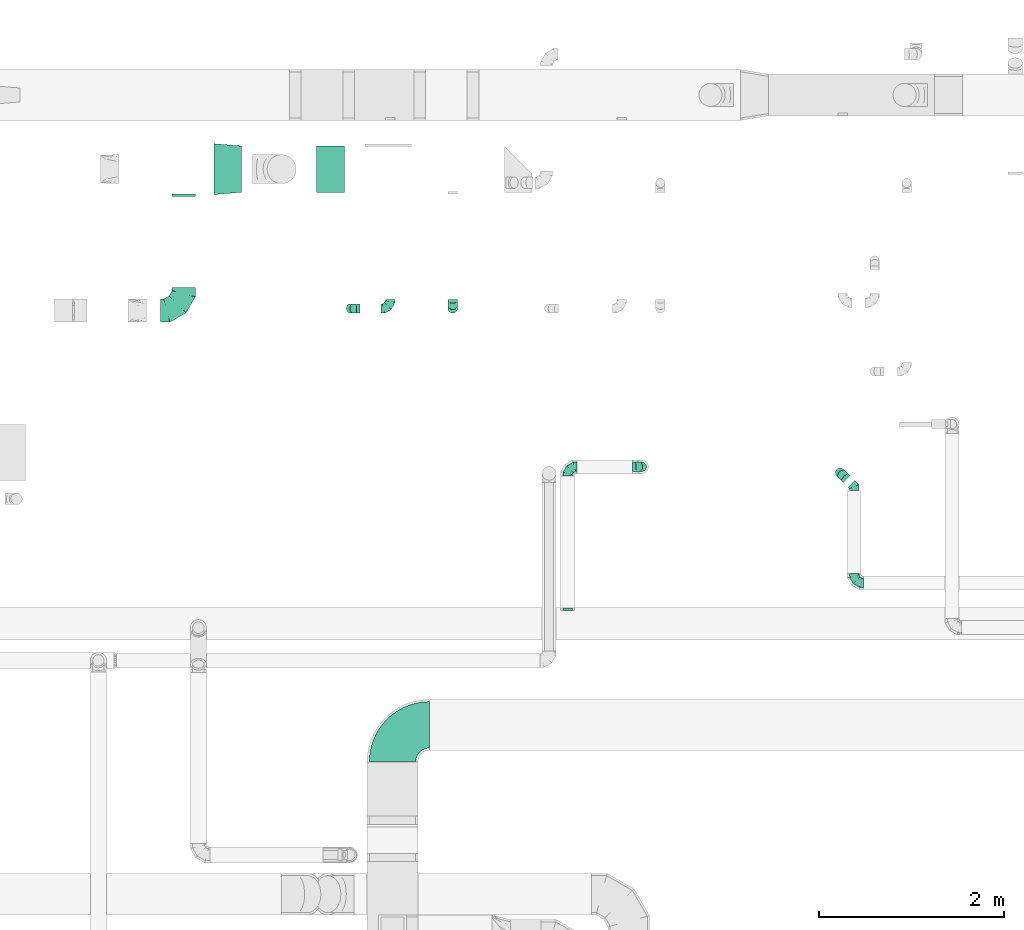
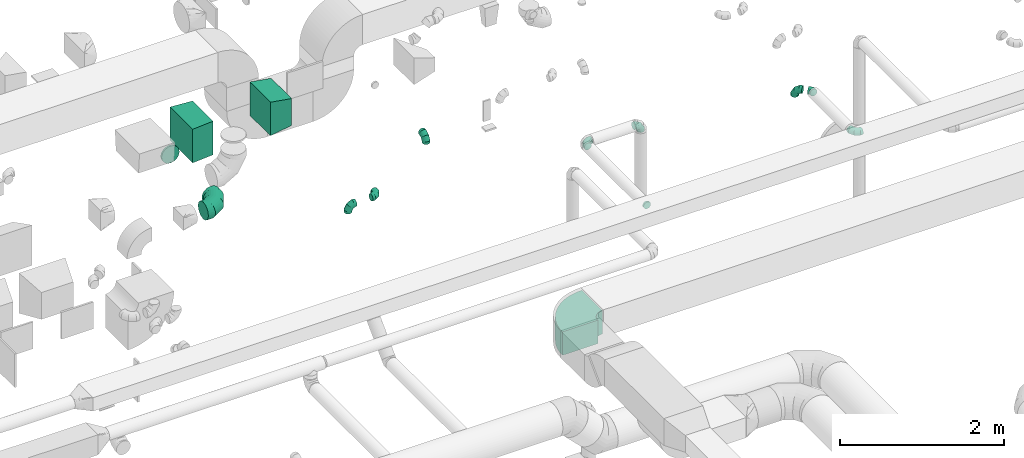
# One storey, part 59 of 97: 14 flow fittings.
"""IFC2X3 building model written with IfcOpenShell, lengths in millimetres."""

from ifc_helpers import new_model, entity, si_unit, converted_unit, derived_unit, direction, frame, frame_2d, origin, place, context, subcontext, project, spatial, polyline, circle_curve, parameter, trimmed, segment, composite_curve, outline, extrude, faceted_brep, source, transform, mapped, material, type_object, type_shapes, element, save


model = new_model("IFC2X3")

# Units and contexts
model_context = context("Model", 3, precision=0.01, world=origin(), true_north=direction((6.12303176911189e-17, 1.0)))
body_context = subcontext(model_context, "Body", "Model", "MODEL_VIEW")
ifc_project = project(units=[si_unit("LENGTHUNIT", "METRE", prefix="MILLI"), si_unit("AREAUNIT", "SQUARE_METRE"), si_unit("VOLUMEUNIT", "CUBIC_METRE"), converted_unit("PLANEANGLEUNIT", "DEGREE", entity("IfcRatioMeasure", 0.0174532925199433), si_unit("PLANEANGLEUNIT", "RADIAN"), dimensions=[0, 0, 0, 0, 0, 0, 0]), si_unit("MASSUNIT", "GRAM", prefix="KILO"), derived_unit("MASSDENSITYUNIT", [(si_unit("MASSUNIT", "GRAM", prefix="KILO"), 1), (si_unit("LENGTHUNIT", "METRE"), -3)]), derived_unit("MOMENTOFINERTIAUNIT", [(si_unit("LENGTHUNIT", "METRE"), 4)]), si_unit("TIMEUNIT", "SECOND"), si_unit("FREQUENCYUNIT", "HERTZ"), si_unit("THERMODYNAMICTEMPERATUREUNIT", "DEGREE_CELSIUS"), derived_unit("THERMALTRANSMITTANCEUNIT", [(si_unit("MASSUNIT", "GRAM", prefix="KILO"), 1), (si_unit("THERMODYNAMICTEMPERATUREUNIT", "KELVIN"), -1), (si_unit("TIMEUNIT", "SECOND"), -3)]), derived_unit("VOLUMETRICFLOWRATEUNIT", [(si_unit("LENGTHUNIT", "METRE"), 3), (si_unit("TIMEUNIT", "SECOND"), -1)]), derived_unit("MASSFLOWRATEUNIT", [(si_unit("MASSUNIT", "GRAM", prefix="KILO"), 1), (si_unit("TIMEUNIT", "SECOND"), -1)]), derived_unit("ROTATIONALFREQUENCYUNIT", [(si_unit("TIMEUNIT", "SECOND"), -1)]), si_unit("ELECTRICCURRENTUNIT", "AMPERE"), si_unit("ELECTRICVOLTAGEUNIT", "VOLT"), si_unit("POWERUNIT", "WATT"), si_unit("FORCEUNIT", "NEWTON", prefix="KILO"), si_unit("ILLUMINANCEUNIT", "LUX"), si_unit("LUMINOUSFLUXUNIT", "LUMEN"), si_unit("LUMINOUSINTENSITYUNIT", "CANDELA"), derived_unit("USERDEFINED", [(si_unit("MASSUNIT", "GRAM", prefix="KILO"), -1), (si_unit("LENGTHUNIT", "METRE"), -2), (si_unit("TIMEUNIT", "SECOND"), 3), (si_unit("LUMINOUSFLUXUNIT", "LUMEN"), 1)]), derived_unit("LINEARVELOCITYUNIT", [(si_unit("LENGTHUNIT", "METRE"), 1), (si_unit("TIMEUNIT", "SECOND"), -1)]), si_unit("PRESSUREUNIT", "PASCAL"), derived_unit("USERDEFINED", [(si_unit("LENGTHUNIT", "METRE"), -2), (si_unit("MASSUNIT", "GRAM", prefix="KILO"), 1), (si_unit("TIMEUNIT", "SECOND"), -2)]), derived_unit("LINEARFORCEUNIT", [(si_unit("MASSUNIT", "GRAM", prefix="KILO"), 1), (si_unit("LENGTHUNIT", "METRE"), 1), (si_unit("TIMEUNIT", "SECOND"), -2), (si_unit("LENGTHUNIT", "METRE"), -1)]), derived_unit("PLANARFORCEUNIT", [(si_unit("MASSUNIT", "GRAM", prefix="KILO"), 1), (si_unit("LENGTHUNIT", "METRE"), 1), (si_unit("TIMEUNIT", "SECOND"), -2), (si_unit("LENGTHUNIT", "METRE"), -2)])], contexts=[model_context])

# Site, building, storey
site_placement = place(None, origin())
site = spatial("IfcSite", under=ifc_project, at=site_placement, CompositionType="ELEMENT")
building_placement = place(site_placement, origin())
building = spatial("IfcBuilding", under=site, at=building_placement, CompositionType="ELEMENT")
storey_placement = place(building_placement, frame((0.0, 0.0, -4900.0)))
storey = spatial("IfcBuildingStorey", under=building, at=storey_placement, CompositionType="ELEMENT", Elevation=-4900.0)

# Flow fittings
ifc_material = material()
duct_fitting_type_1 = type_object("IfcDuctFittingType", PredefinedType="NOTDEFINED", material=ifc_material)
shared_shape_1 = source(origin(), body_context, "Body", "SweptSolid", [
    extrude(outline(polyline([(-189.06, -221.94), (115.08, -221.94), (180.84, 172.62), (-106.86, 271.26), (-189.06, -221.94)])), frame((150.0, -250.0, 0.0), z_axis=(0.0, 1.0, 0.0), x_axis=(0.986393923832128, 0.0, -0.16439898730545)), (0.0, 0.0, 1.0), 500.0),
])
type_shapes(duct_fitting_type_1, [shared_shape_1])
flow_fitting_1_placement = place(storey_placement, frame((48645.11, 14548.39, 3800.0)))
element("IfcFlowFitting", 1, at=flow_fitting_1_placement, inside=storey, type_object=duct_fitting_type_1, material=ifc_material, context=body_context, shape_type="MappedRepresentation", body=[
    mapped(shared_shape_1, transform((0.0, 0.0, 0.0), scale=1.0)),
])
duct_fitting_type_2 = type_object("IfcDuctFittingType", PredefinedType="NOTDEFINED", material=ifc_material)
shared_shape_2 = source(origin(), body_context, "Body", "SweptSolid", [
    extrude(outline(polyline([(-172.32, -261.59), (128.72, -261.59), (170.24, 236.68), (-126.64, 286.51), (-172.32, -261.59)])), frame((150.0, 0.0, -250.0), z_axis=(0.0, 0.0, 1.0), x_axis=(0.99654575824488, 0.0830454798537382, 0.0)), (0.0, 0.0, 1.0), 500.0),
])
type_shapes(duct_fitting_type_2, [shared_shape_2])
flow_fitting_2_placement = place(storey_placement, frame((47535.87, 14548.39, 3800.0)))
element("IfcFlowFitting", 2, at=flow_fitting_2_placement, inside=storey, type_object=duct_fitting_type_2, material=ifc_material, context=body_context, shape_type="MappedRepresentation", body=[
    mapped(shared_shape_2, transform((0.0, 0.0, 0.0), scale=1.0)),
])
duct_fitting_type_3 = type_object("IfcDuctFittingType", PredefinedType="NOTDEFINED", material=ifc_material)
shared_shape_3 = source(origin(), body_context, "Body", "Brep", [
    faceted_brep([(-100.0, 0.0, -50.0), (-100.0, -12.94, -48.3), (-100.0, -25.0, -43.3), (-100.0, -35.36, -35.36), (-100.0, -43.3, -25.0), (-100.0, -48.3, -12.94), (-100.0, -50.0, 0.0), (-100.0, -48.3, 12.94), (-100.0, -43.3, 25.0), (-100.0, -35.36, 35.36), (-100.0, -25.0, 43.3), (-100.0, -12.94, 48.3), (-100.0, 0.0, 50.0), (-100.0, 12.94, 48.3), (-100.0, 25.0, 43.3), (-100.0, 35.36, 35.36), (-100.0, 43.3, 25.0), (-100.0, 48.3, 12.94), (-100.0, 50.0, 0.0), (-100.0, 48.3, -12.94), (-100.0, 43.3, -25.0), (-100.0, 35.36, -35.36), (-100.0, 25.0, -43.3), (-100.0, 12.94, -48.3), (-76.67, 12.94, 48.3), (-79.9, 25.0, 43.3), (-73.21, 0.0, 50.0), (-82.68, 35.36, 35.36), (-86.15, 48.3, 12.94), (-86.6, 50.0, 0.0), (-84.81, 43.3, 25.0), (-84.81, 43.3, -25.0), (-82.68, 35.36, -35.36), (-86.15, 48.3, -12.94), (-76.67, 12.94, -48.3), (-73.21, 0.0, -50.0), (-79.9, 25.0, -43.3), (-69.74, -12.94, -48.3), (-66.51, -25.0, -43.3), (-63.73, -35.36, -35.36), (-61.6, -43.3, -25.0), (-60.26, -48.3, -12.94), (-59.81, -50.0, 0.0), (-60.26, -48.3, 12.94), (-61.6, -43.3, 25.0), (-63.73, -35.36, 35.36), (-66.51, -25.0, 43.3), (-69.74, -12.94, 48.3), (-36.27, 36.27, 48.3), (-45.1, 45.1, 43.3), (-26.79, 26.79, 50.0), (-52.68, 52.68, 35.36), (-58.49, 58.49, 25.0), (-62.15, 62.15, 12.94), (-63.4, 63.4, 0.0), (-62.15, 62.15, -12.94), (-58.49, 58.49, -25.0), (-52.68, 52.68, -35.36), (-36.27, 36.27, -48.3), (-26.79, 26.79, -50.0), (-45.1, 45.1, -43.3), (-17.32, 17.32, -48.3), (-8.49, 8.49, -43.3), (-0.91, 0.91, -35.36), (4.9, -4.9, -25.0), (8.56, -8.56, -12.94), (9.81, -9.81, 0.0), (8.56, -8.56, 12.94), (4.9, -4.9, 25.0), (-0.91, 0.91, 35.36), (-8.49, 8.49, 43.3), (-17.32, 17.32, 48.3), (-12.94, 76.67, 48.3), (-25.0, 79.9, 43.3), (0.0, 73.21, 50.0), (-35.36, 82.68, 35.36), (-43.3, 84.81, 25.0), (-48.3, 86.15, 12.94), (-50.0, 86.6, 0.0), (-48.3, 86.15, -12.94), (-43.3, 84.81, -25.0), (-35.36, 82.68, -35.36), (-12.94, 76.67, -48.3), (0.0, 73.21, -50.0), (-25.0, 79.9, -43.3), (12.94, 69.74, -48.3), (25.0, 66.51, -43.3), (35.36, 63.73, -35.36), (43.3, 61.6, -25.0), (48.3, 60.26, -12.94), (50.0, 59.81, 0.0), (48.3, 60.26, 12.94), (43.3, 61.6, 25.0), (35.36, 63.73, 35.36), (25.0, 66.51, 43.3), (12.94, 69.74, 48.3), (-12.94, 100.0, -48.3), (-25.0, 100.0, -43.3), (-35.36, 100.0, -35.36), (-43.3, 100.0, -25.0), (-48.3, 100.0, -12.94), (-50.0, 100.0, 0.0), (-48.3, 100.0, 12.94), (-43.3, 100.0, 25.0), (-35.36, 100.0, 35.36), (-25.0, 100.0, 43.3), (-12.94, 100.0, 48.3), (0.0, 100.0, 50.0), (12.94, 100.0, 48.3), (25.0, 100.0, 43.3), (35.36, 100.0, 35.36), (43.3, 100.0, 25.0), (48.3, 100.0, 12.94), (50.0, 100.0, 0.0), (48.3, 100.0, -12.94), (43.3, 100.0, -25.0), (35.36, 100.0, -35.36), (25.0, 100.0, -43.3), (12.94, 100.0, -48.3), (0.0, 100.0, -50.0)], [[[0, 1, 2, 3, 4, 5, 6, 7, 8, 9, 10, 11, 12, 13, 14, 15, 16, 17, 18, 19, 20, 21, 22, 23]], [[24, 25, 14, 13]], [[26, 24, 13, 12]], [[14, 25, 27, 15]], [[28, 29, 18, 17]], [[30, 28, 17, 16]], [[15, 27, 30, 16]], [[20, 31, 32, 21]], [[33, 31, 20, 19]], [[18, 29, 33, 19]], [[34, 35, 0, 23]], [[36, 34, 23, 22]], [[32, 36, 22, 21]], [[2, 1, 37, 38]], [[3, 2, 38, 39]], [[0, 35, 37, 1]], [[5, 4, 40, 41]], [[6, 5, 41, 42]], [[3, 39, 40, 4]], [[6, 42, 43, 7]], [[7, 43, 44, 8]], [[8, 44, 45, 9]], [[10, 46, 47, 11]], [[11, 47, 26, 12]], [[10, 9, 45, 46]], [[48, 49, 25, 24]], [[50, 48, 24, 26]], [[27, 25, 49, 51]], [[52, 53, 28, 30]], [[51, 52, 30, 27]], [[29, 28, 53, 54]], [[55, 56, 31, 33]], [[54, 55, 33, 29]], [[57, 32, 31, 56]], [[58, 59, 35, 34]], [[60, 58, 34, 36]], [[57, 60, 36, 32]], [[37, 35, 59, 61]], [[38, 37, 61, 62]], [[39, 38, 62, 63]], [[41, 40, 64, 65]], [[42, 41, 65, 66]], [[63, 64, 40, 39]], [[43, 42, 66, 67]], [[44, 43, 67, 68]], [[68, 69, 45, 44]], [[46, 45, 69, 70]], [[47, 46, 70, 71]], [[26, 47, 71, 50]], [[72, 73, 49, 48]], [[74, 72, 48, 50]], [[51, 49, 73, 75]], [[76, 77, 53, 52]], [[75, 76, 52, 51]], [[54, 53, 77, 78]], [[79, 80, 56, 55]], [[78, 79, 55, 54]], [[81, 57, 56, 80]], [[82, 83, 59, 58]], [[84, 82, 58, 60]], [[81, 84, 60, 57]], [[61, 59, 83, 85]], [[62, 61, 85, 86]], [[63, 62, 86, 87]], [[65, 64, 88, 89]], [[66, 65, 89, 90]], [[87, 88, 64, 63]], [[67, 66, 90, 91]], [[68, 67, 91, 92]], [[92, 93, 69, 68]], [[70, 69, 93, 94]], [[71, 70, 94, 95]], [[50, 71, 95, 74]], [[96, 97, 98, 99, 100, 101, 102, 103, 104, 105, 106, 107, 108, 109, 110, 111, 112, 113, 114, 115, 116, 117, 118, 119]], [[72, 74, 107, 106]], [[73, 72, 106, 105]], [[75, 73, 105, 104]], [[77, 76, 103, 102]], [[78, 77, 102, 101]], [[75, 104, 103, 76]], [[78, 101, 100, 79]], [[79, 100, 99, 80]], [[80, 99, 98, 81]], [[96, 119, 83, 82]], [[97, 96, 82, 84]], [[84, 81, 98, 97]], [[83, 119, 118, 85]], [[85, 118, 117, 86]], [[86, 117, 116, 87]], [[88, 115, 114, 89]], [[89, 114, 113, 90]], [[87, 116, 115, 88]], [[91, 90, 113, 112]], [[92, 91, 112, 111]], [[93, 92, 111, 110]], [[95, 94, 109, 108]], [[74, 95, 108, 107]], [[110, 109, 94, 93]]]),
])
type_shapes(duct_fitting_type_3, [shared_shape_3])
for number, where, z_axis, x_axis in (
    (3, (54294.17, 11273.47, 4115.0), (-0.707106781186523, -0.707106781186572, 0.0), (-0.707106781186572, 0.707106781186523, 0.0)),
    (4, (52154.28, 11335.34, 4300.0), (0.0, -1.0, 0.0), (0.0, 0.0, 1.0)),
    (5, (51354.28, 11335.34, 4300.0), (0.0, 0.0, 1.0), (-1.0, 0.0, 0.0)),
    (6, (54446.9, 10083.58, 4115.0), (0.0, 0.0, 1.0), (0.0, -1.0, 0.0)),
    (7, (50114.62, 13043.39, 3800.0), (-1.0, 0.0, 0.0), (0.0, 0.0, 1.0)),
):
    element("IfcFlowFitting", number, at=place(storey_placement, frame(where, z_axis=z_axis, x_axis=x_axis)), inside=storey, type_object=duct_fitting_type_3, material=ifc_material, context=body_context, shape_type="MappedRepresentation", body=[
        mapped(shared_shape_3, transform((0.0, 0.0, 0.0), scale=1.0)),
    ])
flow_fitting_3_placement = place(storey_placement, frame((49439.09, 13043.4, 3150.0)))
element("IfcFlowFitting", 8, at=flow_fitting_3_placement, inside=storey, type_object=duct_fitting_type_3, material=ifc_material, context=body_context, shape_type="MappedRepresentation", body=[
    mapped(shared_shape_3, transform((0.0, 0.0, 0.0), scale=1.0)),
])
flow_fitting_4_placement = place(storey_placement, frame((49014.01, 13043.4, 3150.0), z_axis=(0.0, -1.0, 0.0), x_axis=(-1.0, 0.0, 0.0)))
element("IfcFlowFitting", 9, at=flow_fitting_4_placement, inside=storey, type_object=duct_fitting_type_3, material=ifc_material, context=body_context, shape_type="MappedRepresentation", body=[
    mapped(shared_shape_3, transform((0.0, 0.0, 0.0), scale=1.0)),
])
duct_fitting_type_4 = type_object("IfcDuctFittingType", PredefinedType="NOTDEFINED", material=ifc_material)
shared_shape_4 = source(origin(), body_context, "Body", "Brep", [
    faceted_brep([(-250.0, 0.0, -125.0), (-250.0, -32.35, -120.74), (-250.0, -62.5, -108.25), (-250.0, -88.39, -88.39), (-250.0, -108.25, -62.5), (-250.0, -120.74, -32.35), (-250.0, -125.0, 0.0), (-250.0, -120.74, 32.35), (-250.0, -108.25, 62.5), (-250.0, -88.39, 88.39), (-250.0, -62.5, 108.25), (-250.0, -32.35, 120.74), (-250.0, 0.0, 125.0), (-250.0, 32.35, 120.74), (-250.0, 62.5, 108.25), (-250.0, 88.39, 88.39), (-250.0, 108.25, 62.5), (-250.0, 120.74, 32.35), (-250.0, 125.0, 0.0), (-250.0, 120.74, -32.35), (-250.0, 108.25, -62.5), (-250.0, 88.39, -88.39), (-250.0, 62.5, -108.25), (-250.0, 32.35, -120.74), (-191.68, 32.35, 120.74), (-199.76, 62.5, 108.25), (-183.01, 0.0, 125.0), (-206.7, 88.39, 88.39), (-215.37, 120.74, 32.35), (-216.51, 125.0, 0.0), (-212.02, 108.25, 62.5), (-212.02, 108.25, -62.5), (-206.7, 88.39, -88.39), (-215.37, 120.74, -32.35), (-191.68, 32.35, -120.74), (-183.01, 0.0, -125.0), (-199.76, 62.5, -108.25), (-174.34, -32.35, -120.74), (-166.27, -62.5, -108.25), (-159.33, -88.39, -88.39), (-154.01, -108.25, -62.5), (-150.66, -120.74, -32.35), (-149.52, -125.0, 0.0), (-150.66, -120.74, 32.35), (-154.01, -108.25, 62.5), (-159.33, -88.39, 88.39), (-166.27, -62.5, 108.25), (-174.34, -32.35, 120.74), (-90.67, 90.67, 120.74), (-112.74, 112.74, 108.25), (-66.99, 66.99, 125.0), (-131.69, 131.69, 88.39), (-146.23, 146.23, 62.5), (-155.38, 155.38, 32.35), (-158.49, 158.49, 0.0), (-155.38, 155.38, -32.35), (-146.23, 146.23, -62.5), (-131.69, 131.69, -88.39), (-90.67, 90.67, -120.74), (-66.99, 66.99, -125.0), (-112.74, 112.74, -108.25), (-43.3, 43.3, -120.74), (-21.23, 21.23, -108.25), (-2.28, 2.28, -88.39), (12.26, -12.26, -62.5), (21.4, -21.4, -32.35), (24.52, -24.52, 0.0), (21.4, -21.4, 32.35), (12.26, -12.26, 62.5), (-2.28, 2.28, 88.39), (-21.23, 21.23, 108.25), (-43.3, 43.3, 120.74), (-32.35, 191.68, 120.74), (-62.5, 199.76, 108.25), (0.0, 183.01, 125.0), (-88.39, 206.7, 88.39), (-108.25, 212.02, 62.5), (-120.74, 215.37, 32.35), (-125.0, 216.51, 0.0), (-120.74, 215.37, -32.35), (-108.25, 212.02, -62.5), (-88.39, 206.7, -88.39), (-32.35, 191.68, -120.74), (0.0, 183.01, -125.0), (-62.5, 199.76, -108.25), (32.35, 174.34, -120.74), (62.5, 166.27, -108.25), (88.39, 159.33, -88.39), (108.25, 154.01, -62.5), (120.74, 150.66, -32.35), (125.0, 149.52, 0.0), (120.74, 150.66, 32.35), (108.25, 154.01, 62.5), (88.39, 159.33, 88.39), (62.5, 166.27, 108.25), (32.35, 174.34, 120.74), (-32.35, 250.0, -120.74), (-62.5, 250.0, -108.25), (-88.39, 250.0, -88.39), (-108.25, 250.0, -62.5), (-120.74, 250.0, -32.35), (-125.0, 250.0, 0.0), (-120.74, 250.0, 32.35), (-108.25, 250.0, 62.5), (-88.39, 250.0, 88.39), (-62.5, 250.0, 108.25), (-32.35, 250.0, 120.74), (0.0, 250.0, 125.0), (32.35, 250.0, 120.74), (62.5, 250.0, 108.25), (88.39, 250.0, 88.39), (108.25, 250.0, 62.5), (120.74, 250.0, 32.35), (125.0, 250.0, 0.0), (120.74, 250.0, -32.35), (108.25, 250.0, -62.5), (88.39, 250.0, -88.39), (62.5, 250.0, -108.25), (32.35, 250.0, -120.74), (0.0, 250.0, -125.0)], [[[0, 1, 2, 3, 4, 5, 6, 7, 8, 9, 10, 11, 12, 13, 14, 15, 16, 17, 18, 19, 20, 21, 22, 23]], [[24, 25, 14, 13]], [[26, 24, 13, 12]], [[14, 25, 27, 15]], [[28, 29, 18, 17]], [[30, 28, 17, 16]], [[15, 27, 30, 16]], [[20, 31, 32, 21]], [[33, 31, 20, 19]], [[18, 29, 33, 19]], [[34, 35, 0, 23]], [[36, 34, 23, 22]], [[21, 32, 36, 22]], [[1, 0, 35, 37]], [[2, 1, 37, 38]], [[38, 39, 3, 2]], [[5, 4, 40, 41]], [[6, 5, 41, 42]], [[39, 40, 4, 3]], [[6, 42, 43, 7]], [[7, 43, 44, 8]], [[8, 44, 45, 9]], [[9, 45, 46, 10]], [[10, 46, 47, 11]], [[26, 12, 11, 47]], [[48, 49, 25, 24]], [[50, 48, 24, 26]], [[27, 25, 49, 51]], [[52, 53, 28, 30]], [[51, 52, 30, 27]], [[29, 28, 53, 54]], [[55, 56, 31, 33]], [[54, 55, 33, 29]], [[32, 31, 56, 57]], [[58, 59, 35, 34]], [[60, 58, 34, 36]], [[57, 60, 36, 32]], [[37, 35, 59, 61]], [[38, 37, 61, 62]], [[39, 38, 62, 63]], [[41, 40, 64, 65]], [[42, 41, 65, 66]], [[63, 64, 40, 39]], [[43, 42, 66, 67]], [[44, 43, 67, 68]], [[68, 69, 45, 44]], [[46, 45, 69, 70]], [[47, 46, 70, 71]], [[26, 47, 71, 50]], [[72, 73, 49, 48]], [[74, 72, 48, 50]], [[51, 49, 73, 75]], [[76, 77, 53, 52]], [[75, 76, 52, 51]], [[54, 53, 77, 78]], [[79, 80, 56, 55]], [[78, 79, 55, 54]], [[57, 56, 80, 81]], [[82, 83, 59, 58]], [[84, 82, 58, 60]], [[81, 84, 60, 57]], [[61, 59, 83, 85]], [[62, 61, 85, 86]], [[63, 62, 86, 87]], [[65, 64, 88, 89]], [[66, 65, 89, 90]], [[87, 88, 64, 63]], [[67, 66, 90, 91]], [[68, 67, 91, 92]], [[92, 93, 69, 68]], [[70, 69, 93, 94]], [[71, 70, 94, 95]], [[50, 71, 95, 74]], [[96, 97, 98, 99, 100, 101, 102, 103, 104, 105, 106, 107, 108, 109, 110, 111, 112, 113, 114, 115, 116, 117, 118, 119]], [[72, 74, 107, 106]], [[73, 72, 106, 105]], [[75, 73, 105, 104]], [[77, 76, 103, 102]], [[78, 77, 102, 101]], [[75, 104, 103, 76]], [[78, 101, 100, 79]], [[79, 100, 99, 80]], [[80, 99, 98, 81]], [[84, 97, 96, 82]], [[82, 96, 119, 83]], [[84, 81, 98, 97]], [[83, 119, 118, 85]], [[85, 118, 117, 86]], [[116, 87, 86, 117]], [[88, 115, 114, 89]], [[89, 114, 113, 90]], [[115, 88, 87, 116]], [[91, 90, 113, 112]], [[92, 91, 112, 111]], [[111, 110, 93, 92]], [[95, 94, 109, 108]], [[74, 95, 108, 107]], [[110, 109, 94, 93]]]),
])
type_shapes(duct_fitting_type_4, [shared_shape_4])
flow_fitting_5_placement = place(storey_placement, frame((47210.59, 13020.83, 3800.0)))
element("IfcFlowFitting", 10, at=flow_fitting_5_placement, inside=storey, type_object=duct_fitting_type_4, material=ifc_material, context=body_context, shape_type="MappedRepresentation", body=[
    mapped(shared_shape_4, transform((0.0, 0.0, 0.0), scale=1.0)),
])
duct_fitting_type_5 = type_object("IfcDuctFittingType", PredefinedType="NOTDEFINED", material=ifc_material)
shared_shape_5 = source(origin(), body_context, "Body", "Brep", [
    faceted_brep([(20.0, 32.35, -120.74), (20.0, 62.5, -108.25), (20.0, 88.39, -88.39), (20.0, 108.25, -62.5), (20.0, 120.74, -32.35), (20.0, 125.0, 0.0), (20.0, 120.74, 32.35), (20.0, 108.25, 62.5), (20.0, 88.39, 88.39), (20.0, 62.5, 108.25), (20.0, 32.35, 120.74), (20.0, 0.0, 125.0), (20.0, -32.35, 120.74), (20.0, -62.5, 108.25), (20.0, -88.39, 88.39), (20.0, -108.25, 62.5), (20.0, -120.74, 32.35), (20.0, -125.0, 0.0), (20.0, -120.74, -32.35), (20.0, -108.25, -62.5), (20.0, -88.39, -88.39), (20.0, -62.5, -108.25), (20.0, -32.35, -120.74), (20.0, 0.0, -125.0), (0.0, 0.0, 125.0), (0.0, 32.35, 120.74), (-6.1, 32.35, 120.74), (-6.1, 0.0, 125.0), (0.0, 62.5, 108.25), (-6.1, 62.5, 108.25), (0.0, 88.39, 88.39), (-6.1, 88.39, 88.39), (0.0, 108.25, 62.5), (0.0, 120.74, 32.35), (-6.1, 120.74, 32.35), (-6.1, 108.25, 62.5), (0.0, 125.0, 0.0), (-6.1, 125.0, 0.0), (0.0, 120.74, -32.35), (-6.1, 120.74, -32.35), (0.0, 108.25, -62.5), (-6.1, 108.25, -62.5), (0.0, 88.39, -88.39), (-6.1, 88.39, -88.39), (0.0, 62.5, -108.25), (0.0, 32.35, -120.74), (-6.1, 32.35, -120.74), (-6.1, 62.5, -108.25), (0.0, 0.0, -125.0), (-6.1, 0.0, -125.0), (0.0, -32.35, -120.74), (-6.1, -32.35, -120.74), (0.0, -62.5, -108.25), (-6.1, -62.5, -108.25), (0.0, -88.39, -88.39), (-6.1, -88.39, -88.39), (0.0, -108.25, -62.5), (0.0, -120.74, -32.35), (-6.1, -120.74, -32.35), (-6.1, -108.25, -62.5), (0.0, -125.0, 0.0), (-6.1, -125.0, 0.0), (0.0, -120.74, 32.35), (-6.1, -120.74, 32.35), (0.0, -108.25, 62.5), (-6.1, -108.25, 62.5), (0.0, -88.39, 88.39), (-6.1, -88.39, 88.39), (0.0, -62.5, 108.25), (0.0, -32.35, 120.74), (-6.1, -32.35, 120.74), (-6.1, -62.5, 108.25)], [[[0, 1, 2, 3, 4, 5, 6, 7, 8, 9, 10, 11, 12, 13, 14, 15, 16, 17, 18, 19, 20, 21, 22, 23]], [[24, 11, 10, 25, 26, 27]], [[25, 10, 9, 28, 29, 26]], [[28, 9, 8, 30, 31, 29]], [[32, 7, 6, 33, 34, 35]], [[33, 6, 5, 36, 37, 34]], [[30, 8, 7, 32, 35, 31]], [[36, 5, 4, 38, 39, 37]], [[38, 4, 3, 40, 41, 39]], [[40, 3, 2, 42, 43, 41]], [[44, 1, 0, 45, 46, 47]], [[45, 0, 23, 48, 49, 46]], [[42, 2, 1, 44, 47, 43]], [[48, 23, 22, 50, 51, 49]], [[50, 22, 21, 52, 53, 51]], [[52, 21, 20, 54, 55, 53]], [[56, 19, 18, 57, 58, 59]], [[57, 18, 17, 60, 61, 58]], [[54, 20, 19, 56, 59, 55]], [[60, 17, 16, 62, 63, 61]], [[62, 16, 15, 64, 65, 63]], [[64, 15, 14, 66, 67, 65]], [[68, 13, 12, 69, 70, 71]], [[69, 12, 11, 24, 27, 70]], [[66, 14, 13, 68, 71, 67]], [[49, 51, 53, 55, 59, 58, 61, 63, 65, 67, 71, 70, 27, 26, 29, 31, 35, 34, 37, 39, 41, 43, 47, 46]]]),
])
type_shapes(duct_fitting_type_5, [shared_shape_5])
flow_fitting_6_placement = place(storey_placement, frame((47210.59, 14273.39, 3800.0), z_axis=(0.0, 0.0, -1.0), x_axis=(0.0, -1.0, 0.0)))
element("IfcFlowFitting", 11, at=flow_fitting_6_placement, inside=storey, type_object=duct_fitting_type_5, material=ifc_material, context=body_context, shape_type="MappedRepresentation", body=[
    mapped(shared_shape_5, transform((0.0, 0.0, 0.0), scale=1.0)),
])
duct_fitting_type_6 = type_object("IfcDuctFittingType", PredefinedType="NOTDEFINED", material=ifc_material)
shared_shape_6 = source(origin(), body_context, "Body", "Brep", [
    faceted_brep([(-41.42, 0.0, -50.0), (-41.42, -12.94, -48.3), (-41.42, -25.0, -43.3), (-41.42, -35.36, -35.36), (-41.42, -43.3, -25.0), (-41.42, -48.3, -12.94), (-41.42, -50.0, 0.0), (-41.42, -48.3, 12.94), (-41.42, -43.3, 25.0), (-41.42, -35.36, 35.36), (-41.42, -25.0, 43.3), (-41.42, -12.94, 48.3), (-41.42, 0.0, 50.0), (-41.42, 12.94, 48.3), (-41.42, 25.0, 43.3), (-41.42, 35.36, 35.36), (-41.42, 43.3, 25.0), (-41.42, 48.3, 12.94), (-41.42, 50.0, 0.0), (-41.42, 48.3, -12.94), (-41.42, 43.3, -25.0), (-41.42, 35.36, -35.36), (-41.42, 25.0, -43.3), (-41.42, 12.94, -48.3), (-5.36, 12.94, 48.3), (-10.36, 25.0, 43.3), (0.0, 0.0, 50.0), (-14.64, 35.36, 35.36), (-20.0, 48.3, 12.94), (-20.71, 50.0, 0.0), (-17.94, 43.3, 25.0), (-17.94, 43.3, -25.0), (-14.64, 35.36, -35.36), (-20.0, 48.3, -12.94), (-5.36, 12.94, -48.3), (0.0, 0.0, -50.0), (-10.36, 25.0, -43.3), (5.36, -12.94, -48.3), (10.36, -25.0, -43.3), (14.64, -35.36, -35.36), (17.94, -43.3, -25.0), (20.0, -48.3, -12.94), (20.71, -50.0, 0.0), (20.0, -48.3, 12.94), (17.94, -43.3, 25.0), (14.64, -35.36, 35.36), (10.36, -25.0, 43.3), (5.36, -12.94, 48.3), (29.29, 29.29, 50.0), (20.14, 38.44, 48.3), (11.61, 46.97, 43.3), (4.29, 54.29, 35.36), (-1.33, 59.91, 25.0), (-4.86, 63.44, 12.94), (-6.07, 64.64, 0.0), (-4.86, 63.44, -12.94), (-1.33, 59.91, -25.0), (4.29, 54.29, -35.36), (11.61, 46.97, -43.3), (20.14, 38.44, -48.3), (29.29, 29.29, -50.0), (38.44, 20.14, -48.3), (46.97, 11.61, -43.3), (54.29, 4.29, -35.36), (59.91, -1.33, -25.0), (63.44, -4.86, -12.94), (64.64, -6.07, 0.0), (63.44, -4.86, 12.94), (59.91, -1.33, 25.0), (54.29, 4.29, 35.36), (46.97, 11.61, 43.3), (38.44, 20.14, 48.3)], [[[0, 1, 2, 3, 4, 5, 6, 7, 8, 9, 10, 11, 12, 13, 14, 15, 16, 17, 18, 19, 20, 21, 22, 23]], [[24, 25, 14, 13]], [[26, 24, 13, 12]], [[14, 25, 27, 15]], [[28, 29, 18, 17]], [[30, 28, 17, 16]], [[16, 15, 27, 30]], [[20, 31, 32, 21]], [[33, 31, 20, 19]], [[18, 29, 33, 19]], [[34, 35, 0, 23]], [[36, 34, 23, 22]], [[32, 36, 22, 21]], [[1, 0, 35, 37]], [[2, 1, 37, 38]], [[38, 39, 3, 2]], [[5, 4, 40, 41]], [[6, 5, 41, 42]], [[39, 40, 4, 3]], [[6, 42, 43, 7]], [[7, 43, 44, 8]], [[8, 44, 45, 9]], [[9, 45, 46, 10]], [[10, 46, 47, 11]], [[26, 12, 11, 47]], [[24, 26, 48, 49]], [[25, 24, 49, 50]], [[27, 25, 50, 51]], [[28, 30, 52, 53]], [[29, 28, 53, 54]], [[27, 51, 52, 30]], [[29, 54, 55, 33]], [[33, 55, 56, 31]], [[31, 56, 57, 32]], [[36, 58, 59, 34]], [[34, 59, 60, 35]], [[36, 32, 57, 58]], [[61, 62, 38, 37]], [[60, 61, 37, 35]], [[63, 39, 38, 62]], [[40, 64, 65, 41]], [[41, 65, 66, 42]], [[64, 40, 39, 63]], [[43, 42, 66, 67]], [[44, 43, 67, 68]], [[68, 69, 45, 44]], [[47, 46, 70, 71]], [[26, 47, 71, 48]], [[69, 70, 46, 45]], [[59, 58, 57, 56, 55, 54, 53, 52, 51, 50, 49, 48, 71, 70, 69, 68, 67, 66, 65, 64, 63, 62, 61, 60]]]),
])
type_shapes(duct_fitting_type_6, [shared_shape_6])
flow_fitting_7_placement = place(storey_placement, frame((54446.9, 11120.74, 4115.0), z_axis=(0.0, 0.0, 1.0), x_axis=(0.0, 1.0, 0.0)))
element("IfcFlowFitting", 12, at=flow_fitting_7_placement, inside=storey, type_object=duct_fitting_type_6, material=ifc_material, context=body_context, shape_type="MappedRepresentation", body=[
    mapped(shared_shape_6, transform((0.0, 0.0, 0.0), scale=1.0)),
])
duct_fitting_type_7 = type_object("IfcDuctFittingType", PredefinedType="NOTDEFINED", material=ifc_material)
shared_shape_7 = source(origin(), body_context, "Body", "Brep", [
    faceted_brep([(20.0, 12.94, -48.3), (20.0, 25.0, -43.3), (20.0, 35.36, -35.36), (20.0, 43.3, -25.0), (20.0, 48.3, -12.94), (20.0, 50.0, 0.0), (20.0, 48.3, 12.94), (20.0, 43.3, 25.0), (20.0, 35.36, 35.36), (20.0, 25.0, 43.3), (20.0, 12.94, 48.3), (20.0, 0.0, 50.0), (20.0, -12.94, 48.3), (20.0, -25.0, 43.3), (20.0, -35.36, 35.36), (20.0, -43.3, 25.0), (20.0, -48.3, 12.94), (20.0, -50.0, 0.0), (20.0, -48.3, -12.94), (20.0, -43.3, -25.0), (20.0, -35.36, -35.36), (20.0, -25.0, -43.3), (20.0, -12.94, -48.3), (20.0, 0.0, -50.0), (0.0, 0.0, 50.0), (0.0, 12.94, 48.3), (-6.1, 12.94, 48.3), (-6.1, 0.0, 50.0), (0.0, 25.0, 43.3), (-6.1, 25.0, 43.3), (0.0, 35.36, 35.36), (-6.1, 35.36, 35.36), (0.0, 43.3, 25.0), (0.0, 48.3, 12.94), (-6.1, 48.3, 12.94), (-6.1, 43.3, 25.0), (0.0, 50.0, 0.0), (-6.1, 50.0, 0.0), (0.0, 48.3, -12.94), (-6.1, 48.3, -12.94), (0.0, 43.3, -25.0), (-6.1, 43.3, -25.0), (0.0, 35.36, -35.36), (-6.1, 35.36, -35.36), (0.0, 25.0, -43.3), (0.0, 12.94, -48.3), (-6.1, 12.94, -48.3), (-6.1, 25.0, -43.3), (0.0, 0.0, -50.0), (-6.1, 0.0, -50.0), (0.0, -12.94, -48.3), (-6.1, -12.94, -48.3), (0.0, -25.0, -43.3), (-6.1, -25.0, -43.3), (0.0, -35.36, -35.36), (-6.1, -35.36, -35.36), (0.0, -43.3, -25.0), (0.0, -48.3, -12.94), (-6.1, -48.3, -12.94), (-6.1, -43.3, -25.0), (0.0, -50.0, 0.0), (-6.1, -50.0, 0.0), (0.0, -48.3, 12.94), (-6.1, -48.3, 12.94), (0.0, -43.3, 25.0), (-6.1, -43.3, 25.0), (0.0, -35.36, 35.36), (-6.1, -35.36, 35.36), (0.0, -25.0, 43.3), (0.0, -12.94, 48.3), (-6.1, -12.94, 48.3), (-6.1, -25.0, 43.3)], [[[0, 1, 2, 3, 4, 5, 6, 7, 8, 9, 10, 11, 12, 13, 14, 15, 16, 17, 18, 19, 20, 21, 22, 23]], [[24, 11, 10, 25, 26, 27]], [[25, 10, 9, 28, 29, 26]], [[28, 9, 8, 30, 31, 29]], [[32, 7, 6, 33, 34, 35]], [[33, 6, 5, 36, 37, 34]], [[30, 8, 7, 32, 35, 31]], [[36, 5, 4, 38, 39, 37]], [[38, 4, 3, 40, 41, 39]], [[40, 3, 2, 42, 43, 41]], [[44, 1, 0, 45, 46, 47]], [[45, 0, 23, 48, 49, 46]], [[42, 2, 1, 44, 47, 43]], [[48, 23, 22, 50, 51, 49]], [[50, 22, 21, 52, 53, 51]], [[52, 21, 20, 54, 55, 53]], [[56, 19, 18, 57, 58, 59]], [[57, 18, 17, 60, 61, 58]], [[54, 20, 19, 56, 59, 55]], [[60, 17, 16, 62, 63, 61]], [[62, 16, 15, 64, 65, 63]], [[64, 15, 14, 66, 67, 65]], [[68, 13, 12, 69, 70, 71]], [[69, 12, 11, 24, 27, 70]], [[66, 14, 13, 68, 71, 67]], [[49, 51, 53, 55, 59, 58, 61, 63, 65, 67, 71, 70, 27, 26, 29, 31, 35, 34, 37, 39, 41, 43, 47, 46]]]),
])
type_shapes(duct_fitting_type_7, [shared_shape_7])
flow_fitting_8_placement = place(storey_placement, frame((51354.28, 9793.15, 4300.0), z_axis=(0.0, 0.0, -1.0), x_axis=(0.0, 1.0, 0.0)))
element("IfcFlowFitting", 13, at=flow_fitting_8_placement, inside=storey, type_object=duct_fitting_type_7, material=ifc_material, context=body_context, shape_type="MappedRepresentation", body=[
    mapped(shared_shape_7, transform((0.0, 0.0, 0.0), scale=1.0)),
])
duct_fitting_type_8 = type_object("IfcDuctFittingType", PredefinedType="NOTDEFINED", material=ifc_material)
shared_shape_8 = source(origin(), body_context, "Body", "SweptSolid", [
    extrude(outline(composite_curve([segment(polyline([(-450.0, -200.0), (50.0, -200.0)]), True, "CONTINUOUS"), segment(trimmed(circle_curve(frame_2d((200.0, -200.0), x_axis=(0.0, 1.0)), 150.0), [parameter(0.0)], [parameter(90.0000000000001)], True, "PARAMETER"), False, "CONTINUOUS"), segment(polyline([(200.0, -50.0), (200.0, 450.0)]), True, "CONTINUOUS"), segment(trimmed(circle_curve(frame_2d((200.0, -200.0), x_axis=(0.0, 1.0)), 650.0), [parameter(0.0)], [parameter(90.0000000000001)], True, "PARAMETER"), True, "CONTINUOUS")], self_intersect=False)), frame((-200.0, 200.0, -175.0), z_axis=(0.0, 0.0, 1.0), x_axis=(-1.0, 0.0, 0.0)), (0.0, 0.0, 1.0), 350.0),
])
type_shapes(duct_fitting_type_8, [shared_shape_8])
flow_fitting_9_placement = place(storey_placement, frame((49463.6, 8550.37, 3980.0), z_axis=(0.0, 0.0, 1.0), x_axis=(-1.0, 0.0, 0.0)))
element("IfcFlowFitting", 14, at=flow_fitting_9_placement, inside=storey, type_object=duct_fitting_type_8, material=ifc_material, context=body_context, shape_type="MappedRepresentation", body=[
    mapped(shared_shape_8, transform((0.0, 0.0, 0.0), scale=1.0)),
])

save(model, "model.ifc")
